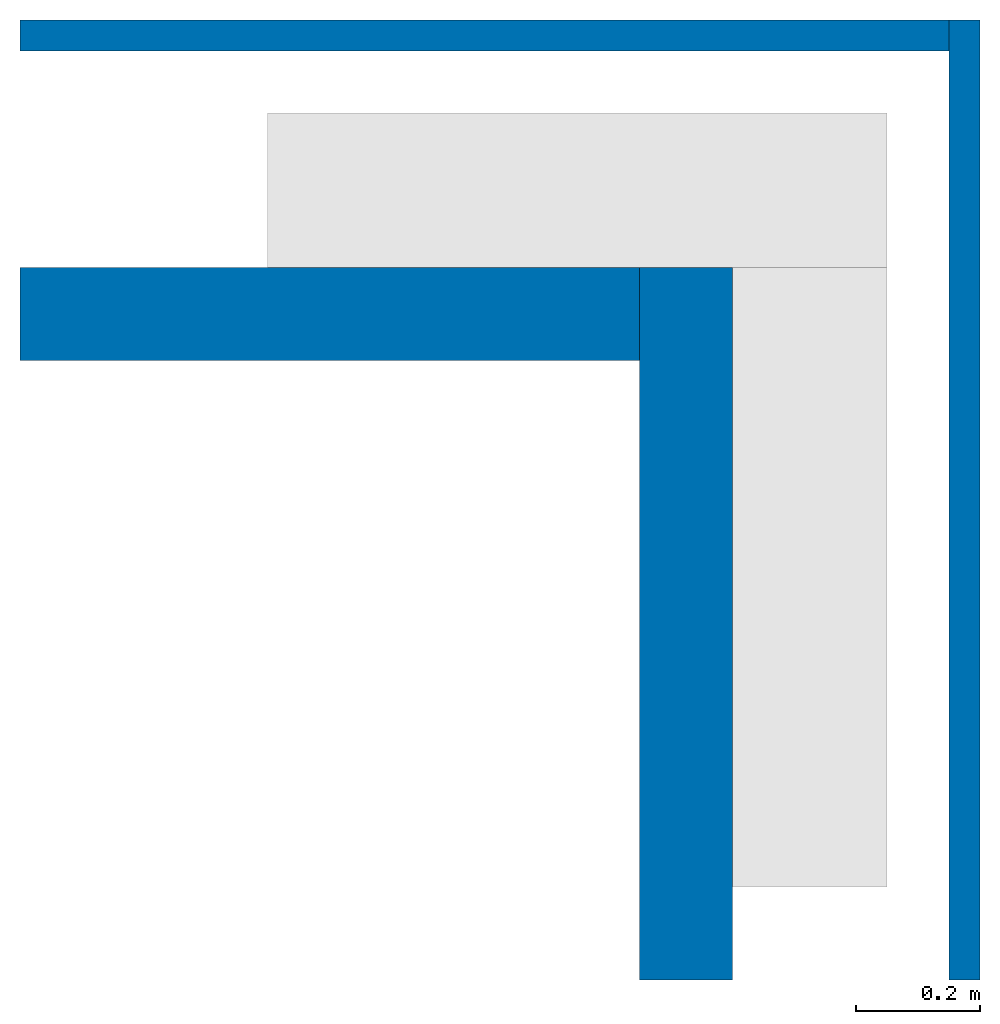
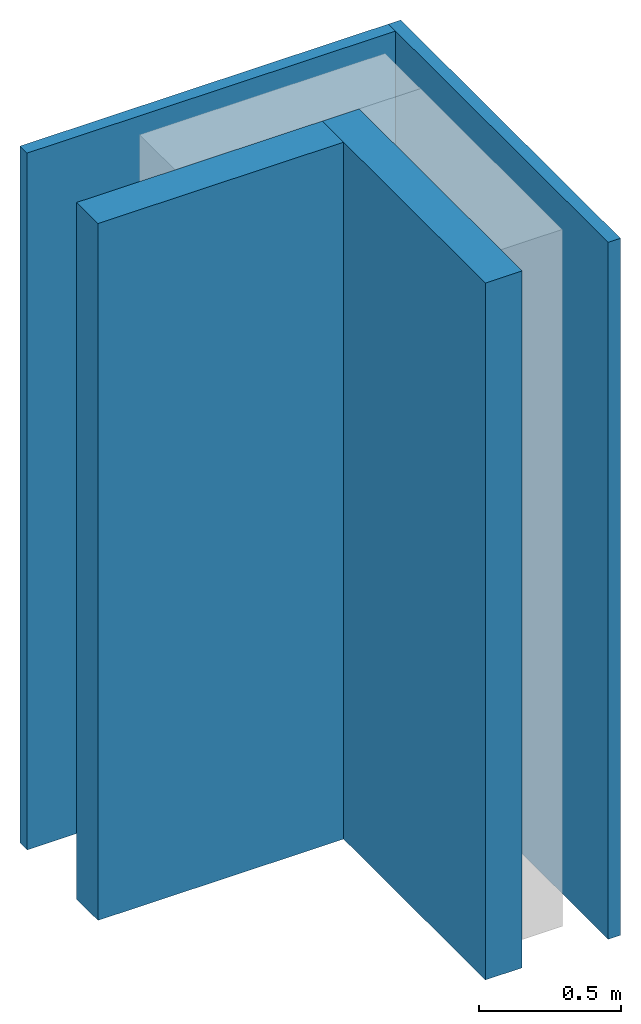
# One storey, part 1 of 2: 4 walls.
"""IFC4 building model written with IfcOpenShell, lengths in metres."""

from ifc_helpers import new_model, entity, si_unit, converted_unit, frame, frame_2d, origin_with_axes, place, context, subcontext, project, spatial, indexed_curve, outline, extrude, material, layer, layer_set, layer_usage, type_object, element, save


model = new_model("IFC4")

# Units and contexts
model_context = context("Model", 3, precision=1e-05, world=origin_with_axes())
plan_context = context("Plan", 2, precision=1e-05, world=frame_2d((0.0, 0.0, 0.0), x_axis=(1.0, 0.0, 0.0)))
context_of_model = context(None, 3, precision=1e-05, world=origin_with_axes())
body_context = subcontext(model_context, "Body", "Model", "MODEL_VIEW")
ifc_project = project(units=[si_unit("VOLUMEUNIT", "CUBIC_METRE"), si_unit("LENGTHUNIT", "METRE"), converted_unit("PLANEANGLEUNIT", "degree", entity("IfcReal", 0.0174532925199433), si_unit("PLANEANGLEUNIT", "RADIAN"), dimensions=[0, 0, 0, 0, 0, 0, 0]), si_unit("AREAUNIT", "SQUARE_METRE")], contexts=[model_context, plan_context, context_of_model])

# Site, building, storey
site_placement = place(None, origin_with_axes())
site = spatial("IfcSite", under=ifc_project, at=site_placement)
building_placement = place(site_placement, origin_with_axes())
building = spatial("IfcBuilding", under=site, at=building_placement, Name="Building")
storey_placement = place(building_placement, origin_with_axes())
storey = spatial("IfcBuildingStorey", under=building, at=storey_placement, Name="Storey")

# Walls
ifc_material_1 = material(Name="concrete")
ifc_layer_1 = layer(ifc_material_1, 0.15)
ifc_layer_set_1 = layer_set([ifc_layer_1], Name="concrete")
ifc_layer_usage_1 = layer_usage(ifc_layer_set_1, "AXIS2", "POSITIVE", 0.0)
wall_type_1 = type_object("IfcWallType", Name="concrete_exterior_wall_150mm", PredefinedType="NOTDEFINED", material=ifc_layer_set_1)
wall_1_placement = place(storey_placement, frame((-1.00000011920929, -0.399999588727951, 0.0), z_axis=(0.0, 0.0, 1.0), x_axis=(1.0, 0.0, 0.0)))
element("IfcWall", 1, at=wall_1_placement, inside=storey, type_object=wall_type_1, material=ifc_layer_usage_1, Name="concrete_exterior_wall_150mm", PredefinedType="NOTDEFINED", context=body_context, shape_type="SweptSolid", body=[
    extrude(outline(indexed_curve([(0.0, 0.0), (0.0, 0.15), (1.0, 0.15), (1.0, 0.0), (0.0, 0.0)], self_intersect=False)), origin_with_axes(), (0.0, 0.0, 1.0), 3.0),
])
ifc_layer_usage_2 = layer_usage(ifc_layer_set_1, "AXIS2", "POSITIVE", 0.0)
wall_2_placement = place(storey_placement, frame((-9.47711882304247e-08, -0.249999582767487, 0.0), z_axis=(0.0, 0.0, 1.0), x_axis=(-1.62920684942947e-07, -1.0, 0.0)))
element("IfcWall", 2, at=wall_2_placement, inside=storey, type_object=wall_type_1, material=ifc_layer_usage_2, Name="concrete_exterior_wall_150mm", PredefinedType="NOTDEFINED", context=body_context, shape_type="SweptSolid", body=[
    extrude(outline(indexed_curve([(0.0, 0.0), (0.0, 0.15), (1.15000009951385, 0.15), (1.15000009951385, 0.0), (0.0, 0.0)], self_intersect=False)), origin_with_axes(), (0.0, 0.0, 1.0), 3.0),
])
ifc_material_2 = material(Name="Material.002")
ifc_layer_2 = layer(ifc_material_2, 0.0500000007450581, ventilated=False, Priority=0)
ifc_layer_set_2 = layer_set([ifc_layer_2], Name="brick")
ifc_layer_usage_3 = layer_usage(ifc_layer_set_2, "AXIS2", "POSITIVE", 0.0)
wall_type_2 = type_object("IfcWallType", Name="brick_interior_wall_50mm", PredefinedType="NOTDEFINED", material=ifc_layer_set_2)
wall_3_placement = place(storey_placement, frame((-1.0, 0.100000388920307, 0.0), z_axis=(0.0, 0.0, 1.0), x_axis=(1.0, -2.38418579101562e-07, 0.0)))
element("IfcWall", 3, at=wall_3_placement, inside=storey, type_object=wall_type_2, material=ifc_layer_usage_3, Name="brick_interior_wall_50mm", PredefinedType="NOTDEFINED", context=body_context, shape_type="SweptSolid", body=[
    extrude(outline(indexed_curve([(0.0, 0.0), (0.0, 0.0500000007450581), (1.50000000000004, 0.0500000007450581), (1.50000000000004, 0.0), (0.0, 0.0)], self_intersect=False)), origin_with_axes(), (0.0, 0.0, 1.0), 3.0),
])
ifc_layer_usage_4 = layer_usage(ifc_layer_set_2, "AXIS2", "POSITIVE", 0.0)
wall_4_placement = place(storey_placement, frame((0.499999970197678, 0.150000035762787, 0.0), z_axis=(0.0, 0.0, 1.0), x_axis=(-1.62920684942947e-07, -1.0, 0.0)))
element("IfcWall", 4, at=wall_4_placement, inside=storey, type_object=wall_type_2, material=ifc_layer_usage_4, Name="brick_interior_wall_50mm", PredefinedType="NOTDEFINED", context=body_context, shape_type="SweptSolid", body=[
    extrude(outline(indexed_curve([(0.0, 0.0), (0.0, 0.0500000007450581), (1.54999974158502, 0.0500000007450581), (1.54999974158502, 0.0), (0.0, 0.0)], self_intersect=False)), origin_with_axes(), (0.0, 0.0, 1.0), 3.0),
])

save(model, "model.ifc")
